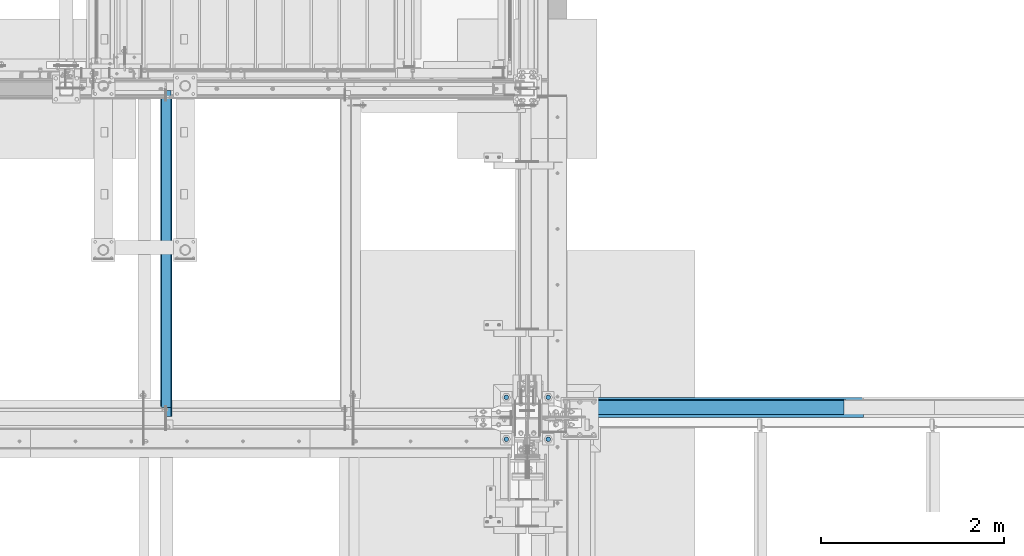
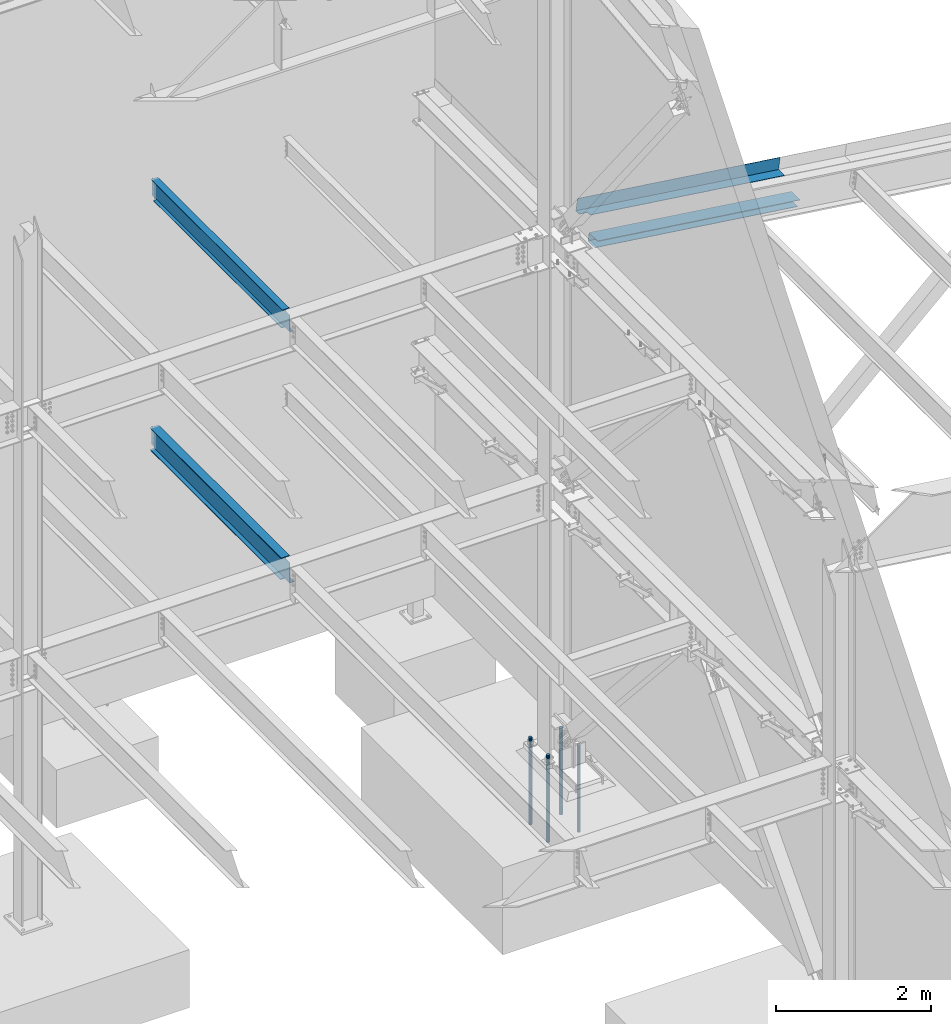
# One storey, part 776 of 1179: 8 beams, 4 elements without a shape of their own.
"""IFC2X3 building model written with IfcOpenShell, lengths in millimetres."""

from ifc_helpers import new_model, si_unit, frame, origin_with_axes, place, context, subcontext, project, spatial, faceted_brep, material, type_object, element, aggregate, save


model = new_model("IFC2X3")

# Units and contexts
model_context = context("Model", 3, precision=1e-05, world=origin_with_axes())
body_context = subcontext(model_context, "Body", "Model", "MODEL_VIEW")
ifc_project = project(units=[si_unit("LENGTHUNIT", "METRE", prefix="MILLI"), si_unit("AREAUNIT", "SQUARE_METRE"), si_unit("VOLUMEUNIT", "CUBIC_METRE"), si_unit("MASSUNIT", "GRAM", prefix="KILO"), si_unit("TIMEUNIT", "SECOND"), si_unit("PLANEANGLEUNIT", "RADIAN"), si_unit("SOLIDANGLEUNIT", "STERADIAN"), si_unit("THERMODYNAMICTEMPERATUREUNIT", "DEGREE_CELSIUS"), si_unit("LUMINOUSINTENSITYUNIT", "LUMEN")], contexts=[model_context])

# Site, building, storey
site_placement = place(None, origin_with_axes())
site = spatial("IfcSite", under=ifc_project, at=site_placement, CompositionType="ELEMENT")
building_placement = place(site_placement, origin_with_axes())
building = spatial("IfcBuilding", under=site, at=building_placement, Name="Undefined", CompositionType="ELEMENT")
storey_placement = place(building_placement, origin_with_axes())
storey = spatial("IfcBuildingStorey", under=building, at=storey_placement, Name="Undefined", CompositionType="ELEMENT", Elevation=0.0)

# Assembly, beam
assembly_1_placement = place(storey_placement, origin_with_axes())
assembly_1 = element("IfcElementAssembly", 1, at=assembly_1_placement, inside=storey, Name="BEAM", AssemblyPlace="NOTDEFINED", PredefinedType="RIGID_FRAME")
ifc_material_1 = material(Name="STEEL/A992")
beam_type_1 = type_object("IfcBeamType", Name="W12X14", PredefinedType="NOTDEFINED")
beam_1_placement = place(assembly_1_placement, frame((20370.8, 34391.6, 7862.8875), z_axis=(0.0, 0.0, 1.0), x_axis=(0.0, 1.0, 0.0)))
beam_1 = element("IfcBeam", 2, at=beam_1_placement, type_object=beam_type_1, material=ifc_material_1, Name="BEAM", ObjectType="W12X14", context=body_context, shape_type="Brep", body=[
    faceted_brep([(104.775000190733, -2.38124999999854, 115.8875), (104.775000190733, 2.38123168416132, 115.8875), (17.4624999999942, 2.38124999999854, 115.8875), (17.4624999999942, -2.38124999999854, 115.8875), (109.63507970878, -2.38124999999854, 116.854229922587), (109.63507970878, 2.38123087677377, 116.854229922587), (113.755256176933, -2.38124999999854, 119.607243823066), (113.755256176933, 2.38122857751659, 119.607243823066), (116.508270077407, -2.38124999999854, 123.727420291219), (116.508270077407, 2.38122513643975, 123.727420291219), (117.474999999999, -2.38124999999854, 128.587499809265), (117.474999999999, 2.38122107741219, 128.587499809265), (117.474999999999, -50.7999999999993, 150.8125), (117.474999999999, 50.7999999999993, 150.8125), (117.474999999999, 50.7999999999993, 144.4625), (117.474999999999, 2.38124999999854, 144.4625), (117.474999999999, -2.38124999999854, 144.4625), (117.474999999999, -50.7999999999993, 144.4625), (3451.22500000001, 2.38124999999854, -144.4625), (3451.22500000001, 50.7999999999993, -144.4625), (144.462499999994, 50.7999999999993, -144.4625), (144.462499999994, 2.38174991607593, -144.4625), (17.4624999999942, -2.38124999999854, -144.4625), (17.4624999999942, -50.7999999999993, -144.4625), (3578.22500000001, -50.7999999999993, -144.4625), (3578.22500000001, -2.38124999999854, -144.4625), (17.4624999999942, -50.7999999999993, -150.8125), (3578.22500000001, -50.7999999999993, -150.8125), (3451.22500000001, 50.7999999999993, -150.8125), (3451.22500000001, 2.38186894147293, -150.8125), (3578.22500000001, 2.38186894147293, -150.8125), (17.4624999999942, 2.38174991607593, -150.8125), (144.462499999994, 2.38174991607593, -150.8125), (144.462499999994, 50.7999999999993, -150.8125), (17.4624999999942, 2.38124999999854, -144.4625), (3578.22500000001, 2.38124999999854, -144.4625), (3578.22500000001, 2.38124999999854, 125.4125), (3578.22500000001, -2.38124999999854, 125.4125), (3530.59999980927, 2.38124999999854, 125.4125), (3530.59999980927, -2.38124999999854, 125.4125), (3525.73992029123, 2.38124999999854, 126.379229922588), (3525.73992029123, -2.38124999999854, 126.379229922588), (3521.61974382307, 2.38124999999854, 129.132243823066), (3521.61974382307, -2.38124999999854, 129.132243823066), (3518.8667299226, 2.38124999999854, 133.25242029122), (3518.8667299226, -2.38124999999854, 133.25242029122), (3517.90000000001, 2.38124999999854, 138.112499809266), (3517.90000000001, -2.38124999999854, 138.112499809266), (3517.90000000001, -50.7999999999993, 150.8125), (3517.90000000001, -50.7999999999993, 144.4625), (3517.90000000001, -2.38124999999854, 144.4625), (3517.90000000001, 2.38124999999854, 144.4625), (3517.90000000001, 50.7999999999993, 144.4625), (3517.90000000001, 50.7999999999993, 150.8125)], [[[0, 1, 2, 3]], [[4, 5, 1, 0]], [[6, 7, 5, 4]], [[8, 9, 7, 6]], [[10, 11, 9, 8]], [[12, 13, 14, 15, 11, 10, 16, 17]], [[18, 19, 20, 21]], [[22, 23, 24, 25]], [[23, 26, 27, 24]], [[28, 29, 30, 27, 26, 31, 32, 33]], [[21, 32, 31, 34]], [[20, 33, 32, 21]], [[19, 28, 33, 20]], [[18, 29, 28, 19]], [[35, 30, 29, 18]], [[25, 24, 27, 30, 35, 36, 37]], [[37, 36, 38, 39]], [[39, 38, 40, 41]], [[41, 40, 42, 43]], [[43, 42, 44, 45]], [[45, 44, 46, 47]], [[48, 49, 50, 47, 46, 51, 52, 53]], [[49, 48, 12, 17]], [[50, 49, 17, 16]], [[8, 6, 4, 0, 3, 22, 25, 37, 39, 41, 43, 45, 47, 50, 16, 10]], [[34, 31, 26, 23, 22, 3, 2]], [[51, 46, 44, 42, 40, 38, 36, 35, 18, 21, 34, 2, 1, 5, 7, 9, 11, 15]], [[52, 51, 15, 14]], [[53, 52, 14, 13]], [[48, 53, 13, 12]]]),
])
aggregate(assembly_1, [beam_1])

# Assembly, beams
assembly_2_placement = place(storey_placement, origin_with_axes())
assembly_2 = element("IfcElementAssembly", 3, at=assembly_2_placement, inside=storey, Name="BEAM", AssemblyPlace="NOTDEFINED", PredefinedType="RIGID_FRAME")
ifc_material_2 = material(Name="STEEL/A36")
beam_type_2 = type_object("IfcBeamType", PredefinedType="NOTDEFINED")
beam_2_placement = place(assembly_2_placement, frame((26275.385431315, 34591.625, 7963.18661013272), z_axis=(0.99100656965293, 0.0, -0.133813223953134), x_axis=(-0.133813222971046, 0.0, -0.991006569785539)))
beam_2 = element("IfcBeam", 4, at=beam_2_placement, type_object=beam_type_2, material=ifc_material_2, Name="BENT_PLATE", context=body_context, shape_type="Brep", body=[
    faceted_brep([(190.500000000875, -87.3124999999054, -1396.2741279923), (184.150000000873, -87.3124999999054, -1396.27412799229), (184.150000000784, -87.3124999999054, -1524.00000000068), (190.5000000008, -87.3124999999054, -1524.00000000069), (190.500000001242, -157.162499998165, -1396.27412799225), (184.15000000124, -157.162499997503, -1396.27412799224), (0.0, 3.17499999999927, -1524.0), (6.00266503170133e-10, 3.17500000077416, 1524.00000000052), (190.499999999047, 3.17500000000291, 1524.00000000002), (190.499999995205, 3.17500000000291, -1524.00000000064), (0.0, -3.17499999999927, -1524.0), (6.00266503170133e-10, -3.17499999922438, 1524.00000000052), (184.149999995203, -3.17500000000291, -1524.00000000063), (184.14999999911, -3.17500000000291, 1524.00000000003), (184.150000003377, -157.162499999082, 1523.99999999995), (190.500000003378, -157.162499999082, 1523.99999999994)], [[[0, 1, 2, 3]], [[4, 5, 1, 0]], [[6, 7, 8, 9]], [[10, 11, 7, 6]], [[11, 10, 12, 13]], [[8, 7, 11, 13, 14, 15]], [[3, 9, 8, 15, 4, 0]], [[12, 10, 6, 9, 3, 2]], [[14, 13, 12, 2, 1, 5]], [[15, 14, 5, 4]]]),
])
beam_type_3 = type_object("IfcBeamType", PredefinedType="NOTDEFINED")
beam_3_placement = place(assembly_2_placement, frame((26463.0091309152, 34398.7437500032, 7340.34090784976), z_axis=(-0.99100656978554, 0.0, 0.133813222971043), x_axis=(0.0, 1.0, 0.0)))
beam_3 = element("IfcBeam", 5, at=beam_3_placement, type_object=beam_type_3, material=ifc_material_2, Name="BENT_PLATE", context=body_context, shape_type="Brep", body=[
    faceted_brep([(0.0, -3.17499999999927, -1524.0), (6.00266503170133e-10, -3.17499999922438, 1524.00000000052), (6.00266503170133e-10, 3.17500000077416, 1524.00000000052), (0.0, 3.17499999999927, -1524.0), (215.106250000514, 3.17500000186192, 1524.00000000029), (215.106250001358, 3.17500000270411, -1524.00000000037), (221.456250001364, -3.17499999723077, -1524.00000000038), (221.45625000052, -3.17499999807296, 1524.00000000029), (215.106250001285, 117.474845395251, 1524.00000000048), (215.106250000594, 117.474845398327, -1524.00000000018), (221.456250000592, 123.824845691788, -1524.00000000017), (221.456250001283, 123.82484568871, 1524.00000000049), (35.718750287866, 117.474837105501, 1524.00000000057), (35.7187502863089, 117.474837107728, -1524.00000000009), (35.7187499944121, 123.824837105503, 1524.00000000059), (35.718749992855, 123.82483710773, -1524.00000000008)], [[[0, 1, 2, 3]], [[3, 2, 4, 5]], [[1, 0, 6, 7]], [[5, 4, 8, 9]], [[7, 6, 10, 11]], [[9, 8, 12, 13]], [[8, 4, 2, 1, 7, 11, 14, 12]], [[11, 10, 15, 14]], [[10, 6, 0, 3, 5, 9, 13, 15]], [[14, 15, 13, 12]]]),
])
aggregate(assembly_2, [beam_2, beam_3])

# Assembly, beam
assembly_3_placement = place(storey_placement, origin_with_axes())
assembly_3 = element("IfcElementAssembly", 6, at=assembly_3_placement, inside=storey, Name="BEAM", AssemblyPlace="NOTDEFINED", PredefinedType="RIGID_FRAME")
beam_type_4 = type_object("IfcBeamType", Name="W14X26", PredefinedType="NOTDEFINED")
beam_4_placement = place(assembly_3_placement, frame((20370.8, 34391.6, 3925.8875), z_axis=(0.0, 0.0, 1.0), x_axis=(0.0, 1.0, 0.0)))
beam_4 = element("IfcBeam", 7, at=beam_4_placement, type_object=beam_type_4, material=ifc_material_1, Name="BEAM", ObjectType="W14X26", context=body_context, shape_type="Brep", body=[
    faceted_brep([(3517.90000000001, -3.17499999999927, -165.1), (3517.90000000001, -63.5, -165.1), (3517.90000000001, -63.5, -176.2125), (3517.90000000001, 63.5, -176.2125), (3517.90000000001, 63.5, -165.1), (3517.90000000001, 3.17499999999927, -165.1), (3517.90000000001, 3.17522060269766, -160.337499809265), (3517.90000000001, -3.17499999999927, -160.337499809265), (3518.8667299226, 3.17521691094589, -155.47742029122), (3518.8667299226, -3.17499999999927, -155.47742029122), (3521.61974382307, 3.17521378168021, -151.357243823066), (3521.61974382307, -3.17499999999927, -151.357243823066), (3525.73992029123, 3.1752116913085, -148.604229922588), (3525.73992029123, -3.17499999999927, -148.604229922588), (3530.59999980927, 3.1752109580666, -147.6375), (3530.59999980927, -3.17499999999927, -147.6375), (3578.22500000001, -3.17499999999927, -147.6375), (3578.22500000001, 3.17499999999927, -147.6375), (3517.90000000001, 63.5, 165.1), (3517.90000000001, 3.17499999999927, 165.1), (127.793749999997, 3.17499999999927, 165.1), (127.793749999997, 63.5, 165.1), (145.256249999999, 63.5, -165.1), (145.256249999999, 63.5, -176.2125), (145.256249999999, 3.17549991607666, -176.2125), (145.256249999999, 3.17549991607666, -165.1), (18.2562499999985, 3.17549991607666, -176.2125), (18.2562499999985, 3.17499999999927, -165.1), (18.2562499999985, -63.5, -176.2125), (18.2562499999985, -63.5, -165.1), (18.2562499999985, -3.17499999999927, -165.1), (18.2562499999985, -3.17499999999927, 144.462500000001), (18.2562499999985, 3.17499999999927, 144.462500000001), (115.093750190732, -3.17499999999927, 144.462500000001), (115.093750190732, 3.17498947558488, 144.462500000001), (119.953829708778, -3.17499999999927, 145.429229922589), (119.953829708778, 3.17498874314697, 145.429229922589), (124.074006176932, -3.17499999999927, 148.182243823067), (124.074006176932, 3.17498665734092, 148.182243823067), (126.827020077406, -3.17499999999927, 152.30242029122), (126.827020077406, 3.17498353571136, 152.30242029122), (127.793749999997, -3.17499999999927, 157.162499809266), (127.793749999997, 3.17497985349837, 157.162499809266), (3517.90000000001, -63.5, 176.2125), (3517.90000000001, 63.5, 176.2125), (127.793749999997, 63.5, 176.2125), (127.793749999997, -63.5, 176.2125), (3517.90000000001, -63.5, 165.1), (127.793749999997, -63.5, 165.1), (3517.90000000001, -3.17499999999927, 165.1), (127.793749999997, -3.17499999999927, 165.1), (3517.90000000001, -3.17499999999927, 160.337499809265), (3517.90000000001, 3.17499999999927, 160.337499809265), (3518.8667299226, -3.17499999999927, 155.477420291219), (3518.8667299226, 3.17499999999927, 155.477420291219), (3521.61974382307, -3.17499999999927, 151.357243823066), (3521.61974382307, 3.17499999999927, 151.357243823066), (3525.73992029123, -3.17499999999927, 148.604229922588), (3525.73992029123, 3.17499999999927, 148.604229922588), (3530.59999980927, -3.17499999999927, 147.6375), (3530.59999980927, 3.17499999999927, 147.6375), (3578.22500000001, -3.17499999999927, 147.6375), (3578.22500000001, 3.17499999999927, 147.6375)], [[[0, 1, 2, 3, 4, 5, 6, 7]], [[7, 6, 8, 9]], [[9, 8, 10, 11]], [[11, 10, 12, 13]], [[13, 12, 14, 15]], [[16, 15, 14, 17]], [[18, 19, 20, 21]], [[22, 23, 24, 25]], [[25, 24, 26, 27]], [[27, 26, 28, 29, 30, 31, 32]], [[33, 34, 32, 31]], [[35, 36, 34, 33]], [[37, 38, 36, 35]], [[39, 40, 38, 37]], [[41, 42, 40, 39]], [[43, 44, 45, 46]], [[47, 43, 46, 48]], [[49, 47, 48, 50]], [[46, 45, 21, 20, 42, 41, 50, 48]], [[44, 18, 21, 45]], [[43, 47, 49, 51, 52, 19, 18, 44]], [[53, 54, 52, 51]], [[55, 56, 54, 53]], [[57, 58, 56, 55]], [[59, 60, 58, 57]], [[61, 62, 60, 59]], [[62, 61, 16, 17]], [[12, 10, 8, 6, 5, 25, 27, 32, 34, 36, 38, 40, 42, 20, 19, 52, 54, 56, 58, 60, 62, 17, 14]], [[5, 4, 22, 25]], [[4, 3, 23, 22]], [[3, 2, 28, 26, 24, 23]], [[29, 28, 2, 1]], [[30, 29, 1, 0]], [[39, 37, 35, 33, 31, 30, 0, 7, 9, 11, 13, 15, 16, 61, 59, 57, 55, 53, 51, 49, 50, 41]]]),
])
aggregate(assembly_3, [beam_4])

# Assembly, beams
assembly_4_placement = place(storey_placement, origin_with_axes())
assembly_4 = element("IfcElementAssembly", 8, at=assembly_4_placement, inside=storey, Name="TEMPLATE", AssemblyPlace="NOTDEFINED", PredefinedType="RIGID_FRAME")
ifc_material_3 = material(Name="STEEL/F1554-GR.55")
beam_type_5 = type_object("IfcBeamType", PredefinedType="NOTDEFINED")
beam_5_placement = place(assembly_4_placement, frame((24079.2, 34620.2, -355.6), z_axis=(0.0, -1.0, 0.0), x_axis=(0.0, 0.0, -1.0)))
beam_5 = element("IfcBeam", 9, at=beam_5_placement, type_object=beam_type_5, material=ifc_material_3, Name="ANCHOR_ROD", context=body_context, shape_type="Brep", body=[
    faceted_brep([(-257.175, -21.2176223927199, 12.25), (-257.175, -12.25, 21.2176223927163), (-257.175, 0.0, 24.5), (-257.175, 12.25, 21.2176223927163), (-257.175, 21.2176223927199, 12.25), (-257.175, 24.5, 0.0), (-257.175, 21.2176223927199, -12.25), (-257.175, 12.25, -21.2176223927163), (-257.175, 0.0, -24.5), (-257.175, -12.25, -21.2176223927163), (-257.175, -21.2176223927199, -12.25), (-257.175, -24.5, 0.0), (0.0, 24.5, 0.0), (0.0, 21.2176223927163, -12.25), (0.0, 12.25, -21.217622392719), (0.0, 0.0, -24.5), (0.0, -12.25, -21.217622392719), (0.0, -21.2176223927163, -12.25), (0.0, -24.5, 0.0), (0.0, -21.2176223927163, 12.25), (0.0, -12.25, 21.217622392719), (0.0, 0.0, 24.5), (0.0, 12.25, 21.217622392719), (0.0, 21.2176223927163, 12.25), (0.0, -23.466540125788, 9.72015918207308), (0.0, -17.9605122421417, 17.9605122421381), (0.0, -9.72015918207035, 23.4665401257871), (0.0, 0.0, 25.3999999999996), (0.0, 9.72015918207035, 23.4665401257871), (0.0, 17.9605122421417, 17.9605122421381), (0.0, 23.466540125788, 9.72015918207308), (0.0, 25.4000000000015, 0.0), (0.0, 23.466540125788, -9.72015918207308), (0.0, 17.9605122421417, -17.9605122421381), (0.0, 9.72015918207035, -23.4665401257871), (0.0, 0.0, -25.3999999999996), (0.0, -9.72015918207035, -23.4665401257871), (0.0, -17.9605122421417, -17.9605122421381), (0.0, -23.466540125788, -9.72015918207308), (0.0, -25.4000000000015, 0.0), (946.149999999999, -25.4000000000015, 0.0), (946.149999999999, -23.466540125788, 9.72015918207308), (946.149999999999, -17.9605122421417, 17.9605122421381), (946.149999999999, -9.72015918207035, 23.4665401257871), (946.149999999999, 0.0, 25.3999999999996), (946.149999999999, 9.72015918207035, 23.4665401257871), (946.149999999999, 17.9605122421417, 17.9605122421381), (946.149999999999, 23.466540125788, 9.72015918207308), (946.149999999999, 25.4000000000015, 0.0), (946.149999999999, 23.466540125788, -9.72015918207308), (946.149999999999, 17.9605122421417, -17.9605122421381), (946.149999999999, 9.72015918207035, -23.4665401257871), (946.149999999999, 0.0, -25.3999999999996), (946.149999999999, -9.72015918207035, -23.4665401257871), (946.149999999999, -17.9605122421417, -17.9605122421381), (946.149999999999, -23.466540125788, -9.72015918207308), (946.149999999999, -12.2499999999927, 21.217622392719), (946.149999999999, 7.27595761418343e-12, 24.5), (946.149999999999, 12.2500000000073, 21.217622392719), (946.149999999999, 21.2176223927236, 12.25), (946.149999999999, 24.5000000000073, 0.0), (946.149999999999, 21.2176223927236, -12.25), (946.149999999999, 12.2500000000073, -21.217622392719), (946.149999999999, 7.27595761418343e-12, -24.5), (946.149999999999, -12.2499999999927, -21.217622392719), (946.149999999999, -21.217622392709, -12.25), (946.149999999999, -24.4999999999927, 0.0), (946.149999999999, -21.217622392709, 12.25), (1117.6, -12.2499999999927, -21.217622392719), (1117.6, 7.27595761418343e-12, -24.5), (1117.6, 12.2500000000073, -21.217622392719), (1117.6, 21.2176223927236, -12.25), (1117.6, 24.5000000000073, 0.0), (1117.6, 21.2176223927236, 12.25), (1117.6, 12.2500000000073, 21.217622392719), (1117.6, 7.27595761418343e-12, 24.5), (1117.6, -12.2499999999927, 21.217622392719), (1117.6, -21.217622392709, 12.25), (1117.6, -24.4999999999927, 0.0), (1117.6, -21.217622392709, -12.25)], [[[0, 1, 2, 3, 4, 5, 6, 7, 8, 9, 10, 11]], [[6, 5, 12, 13]], [[7, 6, 13, 14]], [[8, 7, 14, 15]], [[9, 8, 15, 16]], [[10, 9, 16, 17]], [[11, 10, 17, 18]], [[0, 11, 18, 19]], [[1, 0, 19, 20]], [[2, 1, 20, 21]], [[3, 2, 21, 22]], [[4, 3, 22, 23]], [[5, 4, 23, 12]], [[24, 25, 26, 27, 28, 29, 30, 31, 32, 33, 34, 35, 36, 37, 38, 39], [22, 21, 20, 19, 18, 17, 16, 15, 14, 13, 12, 23]], [[24, 39, 40, 41]], [[25, 24, 41, 42]], [[26, 25, 42, 43]], [[27, 26, 43, 44]], [[28, 27, 44, 45]], [[29, 28, 45, 46]], [[30, 29, 46, 47]], [[31, 30, 47, 48]], [[32, 31, 48, 49]], [[33, 32, 49, 50]], [[34, 33, 50, 51]], [[35, 34, 51, 52]], [[36, 35, 52, 53]], [[37, 36, 53, 54]], [[38, 37, 54, 55]], [[39, 38, 55, 40]], [[54, 53, 52, 51, 50, 49, 48, 47, 46, 45, 44, 43, 42, 41, 40, 55], [56, 57, 58, 59, 60, 61, 62, 63, 64, 65, 66, 67]], [[68, 69, 70, 71, 72, 73, 74, 75, 76, 77, 78, 79]], [[76, 75, 57, 56]], [[77, 76, 56, 67]], [[78, 77, 67, 66]], [[79, 78, 66, 65]], [[68, 79, 65, 64]], [[69, 68, 64, 63]], [[70, 69, 63, 62]], [[71, 70, 62, 61]], [[72, 71, 61, 60]], [[73, 72, 60, 59]], [[74, 73, 59, 58]], [[75, 74, 58, 57]]]),
])
beam_6_placement = place(assembly_4_placement, frame((24079.2, 34163.0, -355.6), z_axis=(0.0, -1.0, 0.0), x_axis=(0.0, 0.0, -1.0)))
beam_6 = element("IfcBeam", 10, at=beam_6_placement, type_object=beam_type_5, material=ifc_material_3, Name="ANCHOR_ROD", context=body_context, shape_type="Brep", body=[
    faceted_brep([(-257.175, -21.2176223927199, 12.25), (-257.175, -12.25, 21.2176223927163), (-257.175, 0.0, 24.5), (-257.175, 12.25, 21.2176223927163), (-257.175, 21.2176223927199, 12.25), (-257.175, 24.5, 0.0), (-257.175, 21.2176223927199, -12.25), (-257.175, 12.25, -21.2176223927163), (-257.175, 0.0, -24.5), (-257.175, -12.25, -21.2176223927163), (-257.175, -21.2176223927199, -12.25), (-257.175, -24.5, 0.0), (0.0, 24.5, 0.0), (0.0, 21.2176223927163, -12.25), (0.0, 12.25, -21.217622392719), (0.0, 0.0, -24.5), (0.0, -12.25, -21.217622392719), (0.0, -21.2176223927163, -12.25), (0.0, -24.5, 0.0), (0.0, -21.2176223927163, 12.25), (0.0, -12.25, 21.217622392719), (0.0, 0.0, 24.5), (0.0, 12.25, 21.217622392719), (0.0, 21.2176223927163, 12.25), (0.0, -23.466540125788, 9.72015918207308), (0.0, -17.9605122421417, 17.9605122421381), (0.0, -9.72015918207035, 23.4665401257871), (0.0, 0.0, 25.3999999999996), (0.0, 9.72015918207035, 23.4665401257871), (0.0, 17.9605122421417, 17.9605122421381), (0.0, 23.466540125788, 9.72015918207308), (0.0, 25.4000000000015, 0.0), (0.0, 23.466540125788, -9.72015918207308), (0.0, 17.9605122421417, -17.9605122421381), (0.0, 9.72015918207035, -23.4665401257871), (0.0, 0.0, -25.3999999999996), (0.0, -9.72015918207035, -23.4665401257871), (0.0, -17.9605122421417, -17.9605122421381), (0.0, -23.466540125788, -9.72015918207308), (0.0, -25.4000000000015, 0.0), (946.149999999999, -25.4000000000015, 0.0), (946.149999999999, -23.466540125788, 9.72015918207308), (946.149999999999, -17.9605122421417, 17.9605122421381), (946.149999999999, -9.72015918207035, 23.4665401257871), (946.149999999999, 0.0, 25.3999999999996), (946.149999999999, 9.72015918207035, 23.4665401257871), (946.149999999999, 17.9605122421417, 17.9605122421381), (946.149999999999, 23.466540125788, 9.72015918207308), (946.149999999999, 25.4000000000015, 0.0), (946.149999999999, 23.466540125788, -9.72015918207308), (946.149999999999, 17.9605122421417, -17.9605122421381), (946.149999999999, 9.72015918207035, -23.4665401257871), (946.149999999999, 0.0, -25.3999999999996), (946.149999999999, -9.72015918207035, -23.4665401257871), (946.149999999999, -17.9605122421417, -17.9605122421381), (946.149999999999, -23.466540125788, -9.72015918207308), (946.149999999999, -12.2499999999927, 21.217622392719), (946.149999999999, 7.27595761418343e-12, 24.5), (946.149999999999, 12.2500000000073, 21.217622392719), (946.149999999999, 21.2176223927236, 12.25), (946.149999999999, 24.5000000000073, 0.0), (946.149999999999, 21.2176223927236, -12.25), (946.149999999999, 12.2500000000073, -21.217622392719), (946.149999999999, 7.27595761418343e-12, -24.5), (946.149999999999, -12.2499999999927, -21.217622392719), (946.149999999999, -21.217622392709, -12.25), (946.149999999999, -24.4999999999927, 0.0), (946.149999999999, -21.217622392709, 12.25), (1117.6, -12.2499999999927, -21.217622392719), (1117.6, 7.27595761418343e-12, -24.5), (1117.6, 12.2500000000073, -21.217622392719), (1117.6, 21.2176223927236, -12.25), (1117.6, 24.5000000000073, 0.0), (1117.6, 21.2176223927236, 12.25), (1117.6, 12.2500000000073, 21.217622392719), (1117.6, 7.27595761418343e-12, 24.5), (1117.6, -12.2499999999927, 21.217622392719), (1117.6, -21.217622392709, 12.25), (1117.6, -24.4999999999927, 0.0), (1117.6, -21.217622392709, -12.25)], [[[0, 1, 2, 3, 4, 5, 6, 7, 8, 9, 10, 11]], [[6, 5, 12, 13]], [[7, 6, 13, 14]], [[8, 7, 14, 15]], [[9, 8, 15, 16]], [[10, 9, 16, 17]], [[11, 10, 17, 18]], [[0, 11, 18, 19]], [[1, 0, 19, 20]], [[2, 1, 20, 21]], [[3, 2, 21, 22]], [[4, 3, 22, 23]], [[5, 4, 23, 12]], [[24, 25, 26, 27, 28, 29, 30, 31, 32, 33, 34, 35, 36, 37, 38, 39], [22, 21, 20, 19, 18, 17, 16, 15, 14, 13, 12, 23]], [[24, 39, 40, 41]], [[25, 24, 41, 42]], [[26, 25, 42, 43]], [[27, 26, 43, 44]], [[28, 27, 44, 45]], [[29, 28, 45, 46]], [[30, 29, 46, 47]], [[31, 30, 47, 48]], [[32, 31, 48, 49]], [[33, 32, 49, 50]], [[34, 33, 50, 51]], [[35, 34, 51, 52]], [[36, 35, 52, 53]], [[37, 36, 53, 54]], [[38, 37, 54, 55]], [[39, 38, 55, 40]], [[54, 53, 52, 51, 50, 49, 48, 47, 46, 45, 44, 43, 42, 41, 40, 55], [56, 57, 58, 59, 60, 61, 62, 63, 64, 65, 66, 67]], [[68, 69, 70, 71, 72, 73, 74, 75, 76, 77, 78, 79]], [[76, 75, 57, 56]], [[77, 76, 56, 67]], [[78, 77, 67, 66]], [[79, 78, 66, 65]], [[68, 79, 65, 64]], [[69, 68, 64, 63]], [[70, 69, 63, 62]], [[71, 70, 62, 61]], [[72, 71, 61, 60]], [[73, 72, 60, 59]], [[74, 73, 59, 58]], [[75, 74, 58, 57]]]),
])
beam_7_placement = place(assembly_4_placement, frame((24536.4, 34620.2, -355.6), z_axis=(0.0, 1.0, 0.0), x_axis=(0.0, 0.0, -1.0)))
beam_7 = element("IfcBeam", 11, at=beam_7_placement, type_object=beam_type_5, material=ifc_material_3, Name="ANCHOR_ROD", context=body_context, shape_type="Brep", body=[
    faceted_brep([(-257.175, -21.2176223927199, 12.25), (-257.175, -12.25, 21.2176223927163), (-257.175, 0.0, 24.5), (-257.175, 12.25, 21.2176223927163), (-257.175, 21.2176223927199, 12.25), (-257.175, 24.5, 0.0), (-257.175, 21.2176223927199, -12.25), (-257.175, 12.25, -21.2176223927163), (-257.175, 0.0, -24.5), (-257.175, -12.25, -21.2176223927163), (-257.175, -21.2176223927199, -12.25), (-257.175, -24.5, 0.0), (0.0, 24.5, 0.0), (0.0, 21.2176223927163, -12.25), (0.0, 12.25, -21.217622392719), (0.0, 0.0, -24.5), (0.0, -12.25, -21.217622392719), (0.0, -21.2176223927163, -12.25), (0.0, -24.5, 0.0), (0.0, -21.2176223927163, 12.25), (0.0, -12.25, 21.217622392719), (0.0, 0.0, 24.5), (0.0, 12.25, 21.217622392719), (0.0, 21.2176223927163, 12.25), (0.0, -23.466540125788, 9.72015918207308), (0.0, -17.9605122421417, 17.9605122421381), (0.0, -9.72015918207035, 23.4665401257871), (0.0, 0.0, 25.3999999999996), (0.0, 9.72015918207035, 23.4665401257871), (0.0, 17.9605122421417, 17.9605122421381), (0.0, 23.466540125788, 9.72015918207308), (0.0, 25.4000000000015, 0.0), (0.0, 23.466540125788, -9.72015918207308), (0.0, 17.9605122421417, -17.9605122421381), (0.0, 9.72015918207035, -23.4665401257871), (0.0, 0.0, -25.3999999999996), (0.0, -9.72015918207035, -23.4665401257871), (0.0, -17.9605122421417, -17.9605122421381), (0.0, -23.466540125788, -9.72015918207308), (0.0, -25.4000000000015, 0.0), (946.149999999999, -25.4000000000015, 0.0), (946.149999999999, -23.466540125788, 9.72015918207308), (946.149999999999, -17.9605122421417, 17.9605122421381), (946.149999999999, -9.72015918207035, 23.4665401257871), (946.149999999999, 0.0, 25.3999999999996), (946.149999999999, 9.72015918207035, 23.4665401257871), (946.149999999999, 17.9605122421417, 17.9605122421381), (946.149999999999, 23.466540125788, 9.72015918207308), (946.149999999999, 25.4000000000015, 0.0), (946.149999999999, 23.466540125788, -9.72015918207308), (946.149999999999, 17.9605122421417, -17.9605122421381), (946.149999999999, 9.72015918207035, -23.4665401257871), (946.149999999999, 0.0, -25.3999999999996), (946.149999999999, -9.72015918207035, -23.4665401257871), (946.149999999999, -17.9605122421417, -17.9605122421381), (946.149999999999, -23.466540125788, -9.72015918207308), (946.149999999999, -12.2499999999927, 21.217622392719), (946.149999999999, 7.27595761418343e-12, 24.5), (946.149999999999, 12.2500000000073, 21.217622392719), (946.149999999999, 21.2176223927236, 12.25), (946.149999999999, 24.5000000000073, 0.0), (946.149999999999, 21.2176223927236, -12.25), (946.149999999999, 12.2500000000073, -21.217622392719), (946.149999999999, 7.27595761418343e-12, -24.5), (946.149999999999, -12.2499999999927, -21.217622392719), (946.149999999999, -21.217622392709, -12.25), (946.149999999999, -24.4999999999927, 0.0), (946.149999999999, -21.217622392709, 12.25), (1117.6, -12.2499999999927, -21.217622392719), (1117.6, 7.27595761418343e-12, -24.5), (1117.6, 12.2500000000073, -21.217622392719), (1117.6, 21.2176223927236, -12.25), (1117.6, 24.5000000000073, 0.0), (1117.6, 21.2176223927236, 12.25), (1117.6, 12.2500000000073, 21.217622392719), (1117.6, 7.27595761418343e-12, 24.5), (1117.6, -12.2499999999927, 21.217622392719), (1117.6, -21.217622392709, 12.25), (1117.6, -24.4999999999927, 0.0), (1117.6, -21.217622392709, -12.25)], [[[0, 1, 2, 3, 4, 5, 6, 7, 8, 9, 10, 11]], [[6, 5, 12, 13]], [[7, 6, 13, 14]], [[8, 7, 14, 15]], [[9, 8, 15, 16]], [[10, 9, 16, 17]], [[11, 10, 17, 18]], [[0, 11, 18, 19]], [[1, 0, 19, 20]], [[2, 1, 20, 21]], [[3, 2, 21, 22]], [[4, 3, 22, 23]], [[5, 4, 23, 12]], [[24, 25, 26, 27, 28, 29, 30, 31, 32, 33, 34, 35, 36, 37, 38, 39], [22, 21, 20, 19, 18, 17, 16, 15, 14, 13, 12, 23]], [[24, 39, 40, 41]], [[25, 24, 41, 42]], [[26, 25, 42, 43]], [[27, 26, 43, 44]], [[28, 27, 44, 45]], [[29, 28, 45, 46]], [[30, 29, 46, 47]], [[31, 30, 47, 48]], [[32, 31, 48, 49]], [[33, 32, 49, 50]], [[34, 33, 50, 51]], [[35, 34, 51, 52]], [[36, 35, 52, 53]], [[37, 36, 53, 54]], [[38, 37, 54, 55]], [[39, 38, 55, 40]], [[54, 53, 52, 51, 50, 49, 48, 47, 46, 45, 44, 43, 42, 41, 40, 55], [56, 57, 58, 59, 60, 61, 62, 63, 64, 65, 66, 67]], [[68, 69, 70, 71, 72, 73, 74, 75, 76, 77, 78, 79]], [[76, 75, 57, 56]], [[77, 76, 56, 67]], [[78, 77, 67, 66]], [[79, 78, 66, 65]], [[68, 79, 65, 64]], [[69, 68, 64, 63]], [[70, 69, 63, 62]], [[71, 70, 62, 61]], [[72, 71, 61, 60]], [[73, 72, 60, 59]], [[74, 73, 59, 58]], [[75, 74, 58, 57]]]),
])
beam_8_placement = place(assembly_4_placement, frame((24536.4, 34163.0, -355.6), z_axis=(0.0, 1.0, 0.0), x_axis=(0.0, 0.0, -1.0)))
beam_8 = element("IfcBeam", 12, at=beam_8_placement, type_object=beam_type_5, material=ifc_material_3, Name="ANCHOR_ROD", context=body_context, shape_type="Brep", body=[
    faceted_brep([(-257.175, -21.2176223927199, 12.25), (-257.175, -12.25, 21.2176223927163), (-257.175, 0.0, 24.5), (-257.175, 12.25, 21.2176223927163), (-257.175, 21.2176223927199, 12.25), (-257.175, 24.5, 0.0), (-257.175, 21.2176223927199, -12.25), (-257.175, 12.25, -21.2176223927163), (-257.175, 0.0, -24.5), (-257.175, -12.25, -21.2176223927163), (-257.175, -21.2176223927199, -12.25), (-257.175, -24.5, 0.0), (0.0, 24.5, 0.0), (0.0, 21.2176223927163, -12.25), (0.0, 12.25, -21.217622392719), (0.0, 0.0, -24.5), (0.0, -12.25, -21.217622392719), (0.0, -21.2176223927163, -12.25), (0.0, -24.5, 0.0), (0.0, -21.2176223927163, 12.25), (0.0, -12.25, 21.217622392719), (0.0, 0.0, 24.5), (0.0, 12.25, 21.217622392719), (0.0, 21.2176223927163, 12.25), (0.0, -23.466540125788, 9.72015918207308), (0.0, -17.9605122421417, 17.9605122421381), (0.0, -9.72015918207035, 23.4665401257871), (0.0, 0.0, 25.3999999999996), (0.0, 9.72015918207035, 23.4665401257871), (0.0, 17.9605122421417, 17.9605122421381), (0.0, 23.466540125788, 9.72015918207308), (0.0, 25.4000000000015, 0.0), (0.0, 23.466540125788, -9.72015918207308), (0.0, 17.9605122421417, -17.9605122421381), (0.0, 9.72015918207035, -23.4665401257871), (0.0, 0.0, -25.3999999999996), (0.0, -9.72015918207035, -23.4665401257871), (0.0, -17.9605122421417, -17.9605122421381), (0.0, -23.466540125788, -9.72015918207308), (0.0, -25.4000000000015, 0.0), (946.149999999999, -25.4000000000015, 0.0), (946.149999999999, -23.466540125788, 9.72015918207308), (946.149999999999, -17.9605122421417, 17.9605122421381), (946.149999999999, -9.72015918207035, 23.4665401257871), (946.149999999999, 0.0, 25.3999999999996), (946.149999999999, 9.72015918207035, 23.4665401257871), (946.149999999999, 17.9605122421417, 17.9605122421381), (946.149999999999, 23.466540125788, 9.72015918207308), (946.149999999999, 25.4000000000015, 0.0), (946.149999999999, 23.466540125788, -9.72015918207308), (946.149999999999, 17.9605122421417, -17.9605122421381), (946.149999999999, 9.72015918207035, -23.4665401257871), (946.149999999999, 0.0, -25.3999999999996), (946.149999999999, -9.72015918207035, -23.4665401257871), (946.149999999999, -17.9605122421417, -17.9605122421381), (946.149999999999, -23.466540125788, -9.72015918207308), (946.149999999999, -12.2499999999927, 21.217622392719), (946.149999999999, 7.27595761418343e-12, 24.5), (946.149999999999, 12.2500000000073, 21.217622392719), (946.149999999999, 21.2176223927236, 12.25), (946.149999999999, 24.5000000000073, 0.0), (946.149999999999, 21.2176223927236, -12.25), (946.149999999999, 12.2500000000073, -21.217622392719), (946.149999999999, 7.27595761418343e-12, -24.5), (946.149999999999, -12.2499999999927, -21.217622392719), (946.149999999999, -21.217622392709, -12.25), (946.149999999999, -24.4999999999927, 0.0), (946.149999999999, -21.217622392709, 12.25), (1117.6, -12.2499999999927, -21.217622392719), (1117.6, 7.27595761418343e-12, -24.5), (1117.6, 12.2500000000073, -21.217622392719), (1117.6, 21.2176223927236, -12.25), (1117.6, 24.5000000000073, 0.0), (1117.6, 21.2176223927236, 12.25), (1117.6, 12.2500000000073, 21.217622392719), (1117.6, 7.27595761418343e-12, 24.5), (1117.6, -12.2499999999927, 21.217622392719), (1117.6, -21.217622392709, 12.25), (1117.6, -24.4999999999927, 0.0), (1117.6, -21.217622392709, -12.25)], [[[0, 1, 2, 3, 4, 5, 6, 7, 8, 9, 10, 11]], [[6, 5, 12, 13]], [[7, 6, 13, 14]], [[8, 7, 14, 15]], [[9, 8, 15, 16]], [[10, 9, 16, 17]], [[11, 10, 17, 18]], [[0, 11, 18, 19]], [[1, 0, 19, 20]], [[2, 1, 20, 21]], [[3, 2, 21, 22]], [[4, 3, 22, 23]], [[5, 4, 23, 12]], [[24, 25, 26, 27, 28, 29, 30, 31, 32, 33, 34, 35, 36, 37, 38, 39], [22, 21, 20, 19, 18, 17, 16, 15, 14, 13, 12, 23]], [[24, 39, 40, 41]], [[25, 24, 41, 42]], [[26, 25, 42, 43]], [[27, 26, 43, 44]], [[28, 27, 44, 45]], [[29, 28, 45, 46]], [[30, 29, 46, 47]], [[31, 30, 47, 48]], [[32, 31, 48, 49]], [[33, 32, 49, 50]], [[34, 33, 50, 51]], [[35, 34, 51, 52]], [[36, 35, 52, 53]], [[37, 36, 53, 54]], [[38, 37, 54, 55]], [[39, 38, 55, 40]], [[54, 53, 52, 51, 50, 49, 48, 47, 46, 45, 44, 43, 42, 41, 40, 55], [56, 57, 58, 59, 60, 61, 62, 63, 64, 65, 66, 67]], [[68, 69, 70, 71, 72, 73, 74, 75, 76, 77, 78, 79]], [[76, 75, 57, 56]], [[77, 76, 56, 67]], [[78, 77, 67, 66]], [[79, 78, 66, 65]], [[68, 79, 65, 64]], [[69, 68, 64, 63]], [[70, 69, 63, 62]], [[71, 70, 62, 61]], [[72, 71, 61, 60]], [[73, 72, 60, 59]], [[74, 73, 59, 58]], [[75, 74, 58, 57]]]),
])
aggregate(assembly_4, [beam_5, beam_6, beam_7, beam_8])

save(model, "model.ifc")
